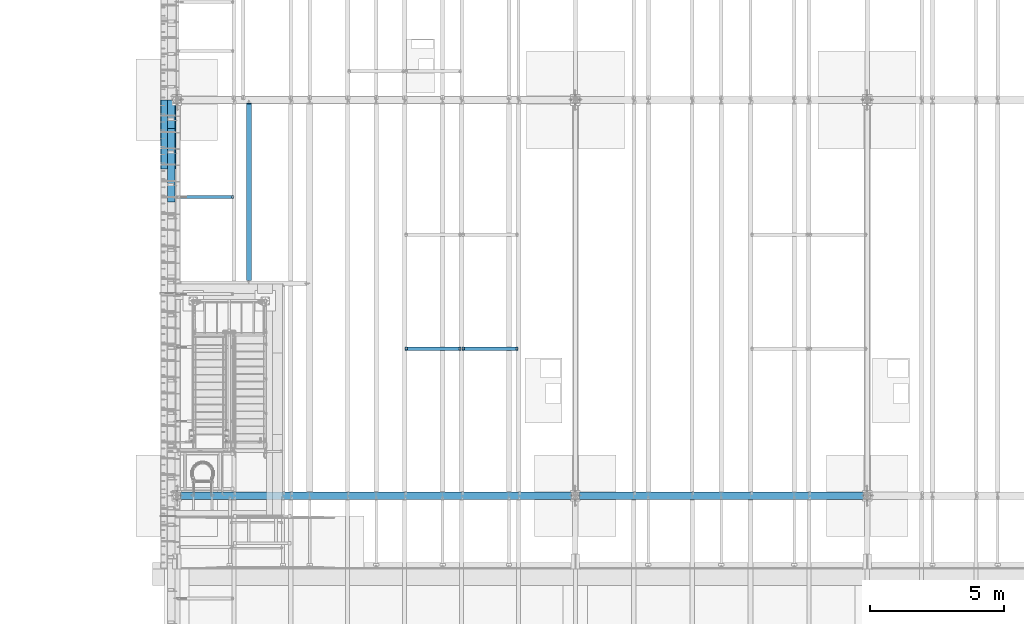
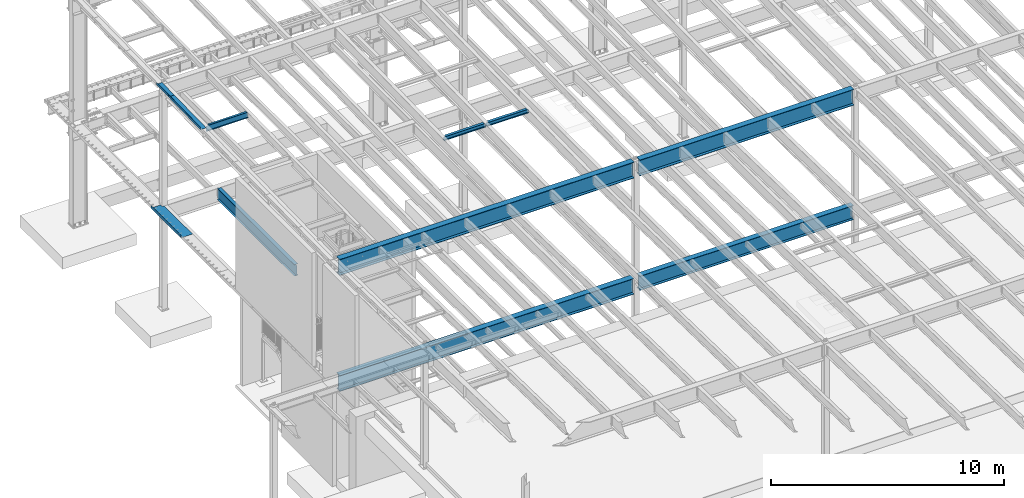
# One storey, part 1096 of 1763: 11 beams, 10 elements without a shape of their own.
"""IFC2X3 building model written with IfcOpenShell, lengths in millimetres."""

from ifc_helpers import new_model, si_unit, frame, origin_with_axes, place, context, subcontext, project, spatial, faceted_brep, material, type_object, element, aggregate, save


model = new_model("IFC2X3")

# Units and contexts
model_context = context("Model", 3, precision=1e-05, world=origin_with_axes())
body_context = subcontext(model_context, "Body", "Model", "MODEL_VIEW")
ifc_project = project(units=[si_unit("LENGTHUNIT", "METRE", prefix="MILLI"), si_unit("AREAUNIT", "SQUARE_METRE"), si_unit("VOLUMEUNIT", "CUBIC_METRE"), si_unit("MASSUNIT", "GRAM", prefix="KILO"), si_unit("TIMEUNIT", "SECOND"), si_unit("PLANEANGLEUNIT", "RADIAN"), si_unit("SOLIDANGLEUNIT", "STERADIAN"), si_unit("THERMODYNAMICTEMPERATUREUNIT", "DEGREE_CELSIUS"), si_unit("LUMINOUSINTENSITYUNIT", "LUMEN")], contexts=[model_context])

# Site, building, storey
site_placement = place(None, origin_with_axes())
site = spatial("IfcSite", under=ifc_project, at=site_placement, CompositionType="ELEMENT")
building_placement = place(site_placement, origin_with_axes())
building = spatial("IfcBuilding", under=site, at=building_placement, Name="Undefined", CompositionType="ELEMENT")
storey_placement = place(building_placement, origin_with_axes())
storey = spatial("IfcBuildingStorey", under=building, at=storey_placement, Name="Undefined", CompositionType="ELEMENT", Elevation=0.0)

# Assembly, beam
assembly_1_placement = place(storey_placement, origin_with_axes())
assembly_1 = element("IfcElementAssembly", 1, at=assembly_1_placement, inside=storey, Name="BEAM", AssemblyPlace="NOTDEFINED", PredefinedType="RIGID_FRAME")
ifc_material_1 = material(Name="STEEL/A992")
beam_type_1 = type_object("IfcBeamType", Name="W8X18", PredefinedType="NOTDEFINED")
beam_1_placement = place(assembly_1_placement, frame((-78870.0658451269, 35509.2, 11300.6242220873), z_axis=(0.0, 0.0, 1.0), x_axis=(1.0, 0.0, 0.0)))
beam_1 = element("IfcBeam", 2, at=beam_1_placement, type_object=beam_type_1, material=ifc_material_1, Name="BEAM", ObjectType="W8X18", context=body_context, shape_type="Brep", body=[
    faceted_brep([(2030.05010096592, -3.17500000000018, 68.5472454972532), (2030.05010096592, 3.17500000000018, 68.5472454972532), (2029.18911617418, 3.17500000000291, 69.8358002989789), (2029.18911617418, -3.17500000000291, 69.8358002989789), (2034.17027743408, -3.17500000000018, 65.7942315967757), (2034.17027743408, 3.17500000000018, 65.7942315967757), (2039.03035695212, -3.17500000000018, 64.8275016741882), (2039.03035695212, 3.17500000000018, 64.8275016741882), (2108.88035714286, -3.17500000000018, 64.8275016741882), (2108.88035714286, 3.17500000000018, 64.8275016741882), (2028.46260401768, -3.17500000000291, 70.3212402021363), (2028.46260401768, 3.17500000000291, 70.3212402021363), (2025.7095901172, 3.17500000000291, 74.44141667029), (2025.7095901172, -3.17500000000291, 74.44141667029), (2024.74286019462, 3.17500000000291, 79.3014961883364), (2024.74286019462, -3.17500000000291, 79.3014961883364), (2024.74286019463, 66.6750000000002, 95.25), (2024.74286019463, 3.17500000000018, 95.25), (101.599996948244, 3.17500000000018, 95.25), (101.599996948244, 66.6750000000002, 95.25), (2024.74286019463, -66.6750000000002, 95.25), (2024.74286019463, -66.6750000000002, 103.1875), (101.599996948244, -66.6750000000002, 103.1875), (101.599996948244, -66.6750000000002, 95.25), (2024.74286019463, 66.6750000000002, 103.1875), (101.599996948244, 66.6750000000002, 103.1875), (2024.74286019463, -3.17500000000018, 95.25), (101.599996948244, -3.17500000000018, 95.25), (101.599996948236, 3.17499999999927, 79.301496189446), (101.599996948236, -3.17499999999927, 79.301496189446), (100.633267025652, 3.17499999999927, 74.4414166713996), (100.633267025652, -3.17499999999927, 74.4414166713996), (97.8802531251713, 3.17499999999927, 70.3212402032459), (97.8802531251713, -3.17499999999927, 70.3212402032459), (97.153740969894, 3.17499999999927, 69.8358003008998), (97.153740969894, -3.17499999999927, 69.8358003008998), (96.2927561769247, 3.17500000000018, 68.5472454911378), (96.2927561769247, -3.17500000000018, 68.5472454911378), (92.1725797087711, 3.17500000000018, 65.7942315906603), (92.1725797087711, -3.17500000000018, 65.7942315906603), (87.3125001907247, 3.17500000000018, 64.8275016680727), (87.3125001907247, -3.17500000000018, 64.8275016680727), (17.4624999999905, 3.17500000000018, 64.8275016680727), (17.4624999999905, -3.17500000000018, 64.8275016680727), (17.4624999999905, 3.17500000000018, -95.25), (17.4624999999905, 66.6750000000002, -95.25), (17.4624999999905, 66.6750000000002, -103.1875), (17.4624999999905, -66.6750000000002, -103.1875), (17.4624999999905, -66.6750000000002, -95.25), (17.4624999999905, -3.17500000000018, -95.25), (2108.88035714286, 3.17500000000018, -95.25), (2108.88035714286, 66.6750000000002, -95.25), (2108.88035714286, 66.6750000000002, -103.1875), (2108.88035714286, -66.6750000000002, -103.1875), (2108.88035714286, -66.6750000000002, -95.25), (2108.88035714286, -3.17500000000018, -95.25)], [[[0, 1, 2, 3]], [[4, 5, 1, 0]], [[6, 7, 5, 4]], [[8, 9, 7, 6]], [[10, 11, 12, 13]], [[13, 12, 14, 15]], [[16, 17, 18, 19]], [[20, 21, 22, 23]], [[21, 24, 25, 22]], [[24, 16, 19, 25]], [[21, 20, 26, 15, 14, 17, 16, 24]], [[26, 20, 23, 27]], [[22, 25, 19, 18, 28, 29, 27, 23]], [[29, 28, 30, 31]], [[31, 30, 32, 33]], [[33, 32, 34, 35]], [[35, 34, 36, 37]], [[37, 36, 38, 39]], [[39, 38, 40, 41]], [[41, 40, 42, 43]], [[44, 45, 46, 47, 48, 49, 43, 42]], [[45, 44, 50, 51]], [[46, 45, 51, 52]], [[47, 46, 52, 53]], [[48, 47, 53, 54]], [[49, 48, 54, 55]], [[4, 0, 3, 10, 13, 15, 26, 27, 29, 31, 33, 35, 37, 39, 41, 43, 49, 55, 8, 6]], [[11, 10, 3, 2]], [[50, 44, 42, 40, 38, 36, 34, 32, 30, 28, 18, 17, 14, 12, 11, 2, 1, 5, 7, 9]], [[55, 54, 53, 52, 51, 50, 9, 8]]]),
])
aggregate(assembly_1, [beam_1])

assembly_2_placement = place(storey_placement, origin_with_axes())
assembly_2 = element("IfcElementAssembly", 3, at=assembly_2_placement, inside=storey, Name="BEAM", AssemblyPlace="NOTDEFINED", PredefinedType="RIGID_FRAME")
beam_2_placement = place(assembly_2_placement, frame((-76743.7229879841, 35509.2, 11300.6242220873), z_axis=(0.0, 0.0, 1.0), x_axis=(1.0, 0.0, 0.0)))
beam_2 = element("IfcBeam", 4, at=beam_2_placement, type_object=beam_type_1, material=ifc_material_1, Name="BEAM", ObjectType="W8X18", context=body_context, shape_type="Brep", body=[
    faceted_brep([(2030.05010096592, -3.17500000000018, 68.5472454972532), (2030.05010096592, 3.17500000000018, 68.5472454972532), (2029.18911617418, 3.17500000000291, 69.8358002989789), (2029.18911617418, -3.17500000000291, 69.8358002989789), (2034.17027743408, -3.17500000000018, 65.7942315967757), (2034.17027743408, 3.17500000000018, 65.7942315967757), (2039.03035695212, -3.17500000000018, 64.8275016741882), (2039.03035695212, 3.17500000000018, 64.8275016741882), (2108.88035714286, -3.17500000000018, 64.8275016741882), (2108.88035714286, 3.17500000000018, 64.8275016741882), (2028.46260401768, -3.17500000000291, 70.3212402021363), (2028.46260401768, 3.17500000000291, 70.3212402021363), (2025.7095901172, 3.17500000000291, 74.44141667029), (2025.7095901172, -3.17500000000291, 74.44141667029), (2024.74286019462, 3.17500000000291, 79.3014961883364), (2024.74286019462, -3.17500000000291, 79.3014961883364), (2024.74286019463, 66.6750000000002, 95.25), (2024.74286019463, 3.17500000000018, 95.25), (101.599996948244, 3.17500000000018, 95.25), (101.599996948244, 66.6750000000002, 95.25), (2024.74286019463, -66.6750000000002, 95.25), (2024.74286019463, -66.6750000000002, 103.1875), (101.599996948244, -66.6750000000002, 103.1875), (101.599996948244, -66.6750000000002, 95.25), (2024.74286019463, 66.6750000000002, 103.1875), (101.599996948244, 66.6750000000002, 103.1875), (2024.74286019463, -3.17500000000018, 95.25), (101.599996948244, -3.17500000000018, 95.25), (101.599996948236, 3.17499999999927, 79.301496189446), (101.599996948236, -3.17499999999927, 79.301496189446), (100.633267025652, 3.17499999999927, 74.4414166713996), (100.633267025652, -3.17499999999927, 74.4414166713996), (97.8802531251713, 3.17499999999927, 70.3212402032459), (97.8802531251713, -3.17499999999927, 70.3212402032459), (97.153740969894, 3.17499999999927, 69.8358003008998), (97.153740969894, -3.17499999999927, 69.8358003008998), (96.2927561769247, 3.17500000000018, 68.5472454911378), (96.2927561769247, -3.17500000000018, 68.5472454911378), (92.1725797087711, 3.17500000000018, 65.7942315906603), (92.1725797087711, -3.17500000000018, 65.7942315906603), (87.3125001907247, 3.17500000000018, 64.8275016680727), (87.3125001907247, -3.17500000000018, 64.8275016680727), (17.4624999999905, 3.17500000000018, 64.8275016680727), (17.4624999999905, -3.17500000000018, 64.8275016680727), (17.4624999999905, 3.17500000000018, -95.25), (17.4624999999905, 66.6750000000002, -95.25), (17.4624999999905, 66.6750000000002, -103.1875), (17.4624999999905, -66.6750000000002, -103.1875), (17.4624999999905, -66.6750000000002, -95.25), (17.4624999999905, -3.17500000000018, -95.25), (2108.88035714286, 3.17500000000018, -95.25), (2108.88035714286, 66.6750000000002, -95.25), (2108.88035714286, 66.6750000000002, -103.1875), (2108.88035714286, -66.6750000000002, -103.1875), (2108.88035714286, -66.6750000000002, -95.25), (2108.88035714286, -3.17500000000018, -95.25)], [[[0, 1, 2, 3]], [[4, 5, 1, 0]], [[6, 7, 5, 4]], [[8, 9, 7, 6]], [[10, 11, 12, 13]], [[13, 12, 14, 15]], [[16, 17, 18, 19]], [[20, 21, 22, 23]], [[21, 24, 25, 22]], [[24, 16, 19, 25]], [[21, 20, 26, 15, 14, 17, 16, 24]], [[26, 20, 23, 27]], [[22, 25, 19, 18, 28, 29, 27, 23]], [[29, 28, 30, 31]], [[31, 30, 32, 33]], [[33, 32, 34, 35]], [[35, 34, 36, 37]], [[37, 36, 38, 39]], [[39, 38, 40, 41]], [[41, 40, 42, 43]], [[44, 45, 46, 47, 48, 49, 43, 42]], [[45, 44, 50, 51]], [[46, 45, 51, 52]], [[47, 46, 52, 53]], [[48, 47, 53, 54]], [[49, 48, 54, 55]], [[4, 0, 3, 10, 13, 15, 26, 27, 29, 31, 33, 35, 37, 39, 41, 43, 49, 55, 8, 6]], [[11, 10, 3, 2]], [[50, 44, 42, 40, 38, 36, 34, 32, 30, 28, 18, 17, 14, 12, 11, 2, 1, 5, 7, 9]], [[55, 54, 53, 52, 51, 50, 9, 8]]]),
])
aggregate(assembly_2, [beam_2])

assembly_3_placement = place(storey_placement, origin_with_axes())
assembly_3 = element("IfcElementAssembly", 5, at=assembly_3_placement, inside=storey, Name="BEAM", AssemblyPlace="NOTDEFINED", PredefinedType="RIGID_FRAME")
ifc_material_2 = material(Name="STEEL/A36")
beam_type_2 = type_object("IfcBeamType", PredefinedType="NOTDEFINED")
beam_3_placement = place(assembly_3_placement, frame((-87413.5372736984, 43510.2, 5199.0625), z_axis=(0.0, -1.0, 0.0), x_axis=(-1.0, 0.0, 0.0)))
beam_3 = element("IfcBeam", 6, at=beam_3_placement, type_object=beam_type_2, material=ifc_material_2, Name="BENT_PLATE", context=body_context, shape_type="Brep", body=[
    faceted_brep([(103.187496948216, -4.76249999999982, -1150.93749743651), (103.187496948216, 4.76249999999982, -1150.93749743651), (103.187496948216, 4.76249999999982, -1292.2245), (103.187496948216, -4.76249999999982, -1292.2245), (0.0, -4.76249999999982, -1150.93749743651), (0.0, 4.76249999999982, -1150.93749743651), (571.5, 4.76249999999982, 1292.2245), (0.0, 4.76249999999982, 1292.2245), (0.0, -4.76249999999982, 1292.2245), (561.975000000006, -4.76249999999982, 1292.2245), (561.975000000006, -134.937496948242, 1292.2245), (571.5, -134.937496948242, 1292.2245), (571.5, 4.76249999999982, -1292.2245), (571.5, -134.937496948242, -1292.2245), (561.975000000006, -134.937496948242, -1292.2245), (561.975000000006, -4.76249999999982, -1292.2245)], [[[0, 1, 2, 3]], [[4, 5, 1, 0]], [[6, 7, 8, 9, 10, 11]], [[12, 6, 11, 13]], [[10, 14, 13, 11]], [[9, 15, 14, 10]], [[12, 13, 14, 15, 3, 2]], [[7, 6, 12, 2, 1, 5]], [[8, 7, 5, 4]], [[15, 9, 8, 4, 0, 3]]]),
])
aggregate(assembly_3, [beam_3])

# Assembly, beams
assembly_4_placement = place(storey_placement, origin_with_axes())
assembly_4 = element("IfcElementAssembly", 7, at=assembly_4_placement, inside=storey, Name="BEAM", AssemblyPlace="NOTDEFINED", PredefinedType="RIGID_FRAME")
beam_type_3 = type_object("IfcBeamType", PredefinedType="NOTDEFINED")
beam_4_placement = place(assembly_4_placement, frame((-87438.9372736983, 44273.9181491461, 11588.3263944835), z_axis=(0.0, -0.999786037781472, -0.0206852279954809), x_axis=(-1.0, 0.0, 0.0)))
beam_4 = element("IfcBeam", 8, at=beam_4_placement, type_object=beam_type_3, material=ifc_material_2, Name="BENT_PLATE", context=body_context, shape_type="Brep", body=[
    faceted_brep([(0.0, -3.17499999985739, -530.112000001536), (-1.45519152283669e-11, -3.17500000014115, 530.112000001522), (0.0, 3.17499999985557, 530.112000001522), (1.45519152283669e-11, 3.17500000013933, -530.112000001536), (285.750000000058, 3.17499999967185, 530.112000001522), (285.750000000102, 3.17499999995562, -530.112000001529), (279.400000000111, -3.17500000003747, -530.112000001529), (279.400000000067, -3.17500000031941, 530.112000001522), (285.750000000087, -123.824997298434, 530.112000001507), (285.750000000087, -123.824997298183, -530.112000001558), (279.400000000081, -123.824997298434, 530.112000001507), (279.400000000081, -123.824997298183, -530.112000001558)], [[[0, 1, 2, 3]], [[3, 2, 4, 5]], [[1, 0, 6, 7]], [[5, 4, 8, 9]], [[4, 2, 1, 7, 10, 8]], [[7, 6, 11, 10]], [[6, 0, 3, 5, 9, 11]], [[10, 11, 9, 8]]]),
])
beam_5_placement = place(assembly_4_placement, frame((-87438.9372736983, 42372.6130436667, 11548.9890481821), z_axis=(0.0, -0.999786037781472, -0.0206852279954809), x_axis=(-1.0, 0.0, 0.0)))
beam_5 = element("IfcBeam", 9, at=beam_5_placement, type_object=beam_type_3, material=ifc_material_2, Name="BENT_PLATE", context=body_context, shape_type="Brep", body=[
    faceted_brep([(2.91038304567337e-11, -3.17499999963729, -1371.60000000396), (-2.91038304567337e-11, -3.17500000036489, 1371.60000000395), (-2.91038304567337e-11, 3.17499999963184, 1371.60000000395), (2.91038304567337e-11, 3.17500000035943, -1371.60000000396), (285.75000000016, 3.17499999930078, 1371.59999999897), (285.750000000276, 3.17499999982283, -1371.59999999897), (279.400000000271, -3.1750000001648, -1371.59999999897), (279.400000000154, -3.17500000068321, 1371.59999999897), (285.750000000218, -123.824997298658, 1371.59999999895), (285.750000000218, -123.824997298212, -1371.59999999898), (279.400000000212, -123.824997298658, 1371.59999999895), (279.400000000212, -123.824997298212, -1371.59999999898)], [[[0, 1, 2, 3]], [[3, 2, 4, 5]], [[1, 0, 6, 7]], [[5, 4, 8, 9]], [[4, 2, 1, 7, 10, 8]], [[7, 6, 11, 10]], [[6, 0, 3, 5, 9, 11]], [[10, 11, 9, 8]]]),
])
aggregate(assembly_4, [beam_4, beam_5])

# Assembly, beam
assembly_5_placement = place(storey_placement, origin_with_axes())
assembly_5 = element("IfcElementAssembly", 10, at=assembly_5_placement, inside=storey, Name="BEAM", AssemblyPlace="NOTDEFINED", PredefinedType="RIGID_FRAME")
beam_type_4 = type_object("IfcBeamType", Name="W12X22", PredefinedType="NOTDEFINED")
beam_6_placement = place(assembly_5_placement, frame((-87375.4372736983, 41182.925, 11365.624133767), z_axis=(0.0, 0.0, 1.0), x_axis=(1.0, 0.0, 0.0)))
beam_6 = element("IfcBeam", 11, at=beam_6_placement, type_object=beam_type_4, material=ifc_material_1, Name="BEAM", ObjectType="W12X22", context=body_context, shape_type="Brep", body=[
    faceted_brep([(18.2562499999913, -3.17499999999927, -144.4625), (18.2562499999913, -50.7999999999993, -144.4625), (2109.67410714286, -50.7999999999993, -144.4625), (2109.67410714286, -3.17499999999927, -144.4625), (18.2562499999913, -50.7999999999993, -155.575000000001), (2109.67410714286, -50.7999999999993, -155.575000000001), (2109.67410714286, 3.17499999999927, -144.4625), (2109.67410714286, 50.7999999999993, -144.4625), (132.556249999994, 50.7999999999993, -144.4625), (132.556249999994, 3.17575008238782, -144.4625), (2033.47410714286, -50.7999999999993, 155.575000000001), (2033.47410714286, -50.7999999999993, 144.4625), (2033.47410714286, -3.17499999999927, 144.4625), (2033.47410714286, -3.17499999999927, 136.265001487105), (2033.47410714286, 3.17499999999927, 136.265001487105), (2033.47410714286, 3.17499999999927, 144.4625), (2033.47410714286, 50.7999999999993, 144.4625), (2033.47410714286, 50.7999999999993, 155.575000000001), (2034.44083706544, -3.17499999999927, 131.404921969059), (2034.44083706544, 3.17499999999927, 131.404921969059), (2037.19385096592, -3.17499999999927, 127.284745500905), (2037.19385096592, 3.17499999999927, 127.284745500905), (2041.31402743408, -3.17499999999927, 124.531731600428), (2041.31402743408, 3.17499999999927, 124.531731600428), (2046.17410695212, -3.17499999999927, 123.56500167784), (2046.17410695212, 3.17499999999927, 123.56500167784), (2109.67410714286, -3.17499999999927, 123.56500167784), (2109.67410714286, 3.17499999999927, 123.56500167784), (2109.67410714286, 50.7999999999993, -155.575000000001), (132.556249999994, 50.7999999999993, -155.575000000001), (132.556249999994, 3.17575008238782, -155.575000000001), (18.2562499999913, 3.17575008238782, -155.575000000001), (18.2562499999913, 3.17499999999927, -144.4625), (124.716329708754, -3.17499999999927, 105.741729925645), (124.716329708754, 3.17500736736474, 105.741729925645), (119.856250190714, 3.1750086254724, 104.775000003057), (119.856250190714, -3.17499999999927, 104.775000003057), (128.836506176915, -3.17499999999927, 108.494743826122), (128.836506176915, 3.17500378457771, 108.494743826122), (131.589520077396, -3.17499999999927, 112.614920294276), (131.589520077396, 3.17499842256075, 112.614920294276), (132.55624999998, -3.17499999999927, 117.474999812322), (132.55624999998, 3.17499209762536, 117.474999812322), (18.2562499999913, 3.17499999999927, -137.353076309833), (18.2562499999913, 3.17499999999927, 104.775000003057), (132.55624999998, 3.17499999999927, 144.4625), (132.55624999998, 50.7999999999993, 144.4625), (132.55624999998, 50.7999999999993, 155.575000000001), (132.55624999998, -50.7999999999993, 155.575000000001), (132.55624999998, -50.7999999999993, 144.4625), (132.55624999998, -3.17499999999927, 144.4625), (18.2562499999913, -3.17499999999927, 104.775000003057)], [[[0, 1, 2, 3]], [[1, 4, 5, 2]], [[6, 7, 8, 9]], [[10, 11, 12, 13, 14, 15, 16, 17]], [[18, 19, 14, 13]], [[20, 21, 19, 18]], [[22, 23, 21, 20]], [[24, 25, 23, 22]], [[26, 27, 25, 24]], [[3, 2, 5, 28, 7, 6, 27, 26]], [[7, 28, 29, 8]], [[8, 29, 30, 9]], [[28, 5, 4, 31, 30, 29]], [[9, 30, 31, 32]], [[33, 34, 35, 36]], [[37, 38, 34, 33]], [[39, 40, 38, 37]], [[41, 42, 40, 39]], [[15, 14, 19, 21, 23, 25, 27, 6, 9, 32, 43, 44, 35, 34, 38, 40, 42, 45]], [[16, 15, 45, 46]], [[17, 16, 46, 47]], [[10, 17, 47, 48]], [[11, 10, 48, 49]], [[12, 11, 49, 50]], [[48, 47, 46, 45, 42, 41, 50, 49]], [[39, 37, 33, 36, 51, 0, 3, 26, 24, 22, 20, 18, 13, 12, 50, 41]], [[43, 32, 31, 4, 1, 0, 51, 44]], [[36, 35, 44, 51]]]),
])
aggregate(assembly_5, [beam_6])

assembly_6_placement = place(storey_placement, origin_with_axes())
assembly_6 = element("IfcElementAssembly", 12, at=assembly_6_placement, inside=storey, Name="BEAM", AssemblyPlace="NOTDEFINED", PredefinedType="RIGID_FRAME")
beam_type_5 = type_object("IfcBeamType", Name="W24X55", PredefinedType="NOTDEFINED")
beam_7_placement = place(assembly_6_placement, frame((-84684.7417063673, 37947.6, 4894.2625), z_axis=(0.0, 0.0, 1.0), x_axis=(0.0, 1.0, 0.0)))
beam_7 = element("IfcBeam", 13, at=beam_7_placement, type_object=beam_type_5, material=ifc_material_1, Name="BEAM", ObjectType="W24X55", context=body_context, shape_type="Brep", body=[
    faceted_brep([(17.4624999999942, -4.76249999999709, -271.7225), (17.4624999999942, 4.76249999999709, -271.7225), (93.6625001907305, 4.76249999999709, -271.7225), (93.6625001907305, -4.76249999999709, -271.7225), (98.5225797087769, 4.76249999999709, -272.689229922587), (98.5225797087769, -4.76249999999709, -272.689229922587), (102.642756176931, 4.76249999999709, -275.442243823066), (102.642756176931, -4.76249999999709, -275.442243823066), (105.395770077404, 4.76249999999709, -279.562420291219), (105.395770077404, -4.76249999999709, -279.562420291219), (106.362499999996, -4.76249999999709, -284.422499809265), (106.362499999996, 4.76249999999709, -284.422499809265), (106.362499999996, 4.76249999999709, -287.3375), (106.362499999996, 88.8999999999942, -287.3375), (106.362499999996, 88.8999999999942, -300.0375), (106.362499999996, -88.8999999999942, -300.0375), (106.362499999996, -88.8999999999942, -287.3375), (106.362499999996, -4.76249999999709, -287.3375), (6698.45624999997, 88.8999999999942, 287.3375), (6698.45624999997, 4.76249999999709, 287.3375), (106.362499999996, 4.76249999999709, 287.3375), (106.362499999996, 88.8999999999942, 287.3375), (93.6625001907305, -4.76249999999709, 268.027501678467), (93.6625001907305, 4.76249999999709, 268.027501678467), (17.4624999999942, 4.76249999999709, 268.027501678467), (17.4624999999942, -4.76249999999709, 268.027501678467), (98.5225797087769, -4.76249999999709, 268.994231601055), (98.5225797087769, 4.76249999999709, 268.994231601055), (102.642756176931, -4.76249999999709, 271.747245501533), (102.642756176931, 4.76249999999709, 271.747245501533), (105.395770077404, -4.76249999999709, 275.867421969687), (105.395770077404, 4.76249999999709, 275.867421969687), (106.362499999996, -4.76249999999709, 280.727501487732), (106.362499999996, 4.76249999999709, 280.727501487732), (6698.45624999997, -88.8999999999942, 300.0375), (6698.45624999997, 88.8999999999942, 300.0375), (106.362499999996, 88.8999999999942, 300.0375), (106.362499999996, -88.8999999999942, 300.0375), (6698.45624999997, -88.8999999999942, 287.3375), (106.362499999996, -88.8999999999942, 287.3375), (6698.45624999997, -4.76249999999709, 287.3375), (106.362499999996, -4.76249999999709, 287.3375), (6698.45624999997, -4.76249999999709, 280.727501487732), (6698.45624999997, 4.76249999999709, 280.727501487732), (6699.42297992256, -4.76249999999709, 275.867421969687), (6699.42297992256, 4.76249999999709, 275.867421969687), (6702.17599382304, -4.76249999999709, 271.747245501533), (6702.17599382304, 4.76249999999709, 271.747245501533), (6706.29617029119, -4.76249999999709, 268.994231601055), (6706.29617029119, 4.76249999999709, 268.994231601055), (6711.15624980924, -4.76249999999709, 268.027501678467), (6711.15624980924, 4.76249999999709, 268.027501678467), (6838.15624999999, -4.76249999999709, 268.027501678467), (6838.15624999999, 4.76249999999709, 268.027501678467), (6736.55624872205, -88.8999999999942, -287.3375), (6736.55624872205, -88.8999999999942, -300.0375), (6736.55622725979, -5.06274543626932, -300.0375), (6736.55622725969, -5.0622513936396, -287.3375), (6838.15624999999, -5.06222538421571, -287.3375), (6838.15624999999, -5.06271942691819, -300.0375), (6736.55622624891, 5.0627455276117, -287.3375), (6736.556226249, 5.06225148496742, -300.0375), (6736.55620478676, 88.8999999999942, -300.0375), (6736.55620478676, 88.8999999999942, -287.3375), (6838.15624999999, 5.06277153702104, -287.3375), (6838.15624999999, 5.06227749431855, -300.0375), (6838.15624999999, 4.76249999999709, -287.3375), (6838.15624999999, -4.76249999999709, -287.3375)], [[[0, 1, 2, 3]], [[3, 2, 4, 5]], [[5, 4, 6, 7]], [[7, 6, 8, 9]], [[10, 11, 12, 13, 14, 15, 16, 17]], [[9, 8, 11, 10]], [[18, 19, 20, 21]], [[22, 23, 24, 25]], [[26, 27, 23, 22]], [[28, 29, 27, 26]], [[30, 31, 29, 28]], [[32, 33, 31, 30]], [[34, 35, 36, 37]], [[38, 34, 37, 39]], [[40, 38, 39, 41]], [[37, 36, 21, 20, 33, 32, 41, 39]], [[35, 18, 21, 36]], [[34, 38, 40, 42, 43, 19, 18, 35]], [[44, 45, 43, 42]], [[46, 47, 45, 44]], [[48, 49, 47, 46]], [[50, 51, 49, 48]], [[52, 53, 51, 50]], [[54, 55, 56, 57]], [[58, 57, 56, 59]], [[60, 61, 62, 63]], [[64, 65, 61, 60]], [[66, 53, 52, 67, 58, 59, 65, 64]], [[54, 57, 58, 67, 17, 16]], [[55, 54, 16, 15]], [[62, 61, 65, 59, 56, 55, 15, 14]], [[63, 62, 14, 13]], [[66, 64, 60, 63, 13, 12]], [[6, 4, 2, 1, 24, 23, 27, 29, 31, 33, 20, 19, 43, 45, 47, 49, 51, 53, 66, 12, 11, 8]], [[25, 24, 1, 0]], [[67, 52, 50, 48, 46, 44, 42, 40, 41, 32, 30, 28, 26, 22, 25, 0, 3, 5, 7, 9, 10, 17]]]),
])
aggregate(assembly_6, [beam_7])

assembly_7_placement = place(storey_placement, origin_with_axes())
assembly_7 = element("IfcElementAssembly", 14, at=assembly_7_placement, inside=storey, Name="BEAM", AssemblyPlace="NOTDEFINED", PredefinedType="RIGID_FRAME")
beam_type_6 = type_object("IfcBeamType", Name="W33X130", PredefinedType="NOTDEFINED")
beam_8_placement = place(assembly_7_placement, frame((-87375.4372736983, 30022.8000001297, 10869.6124999957), z_axis=(0.0, 0.0, 1.0), x_axis=(1.0, 0.0, 0.0)))
beam_8 = element("IfcBeam", 15, at=beam_8_placement, type_object=beam_type_6, material=ifc_material_1, Name="BEAM", ObjectType="W33X130", context=body_context, shape_type="Brep", body=[
    faceted_brep([(141.287500000006, 146.049999999999, -420.6875), (141.287499999999, 146.049999999999, -398.4625), (14743.1125, 146.049999999999, -398.4625), (14743.1125, 146.049999999999, -420.6875), (141.287499999999, 7.14374999999927, -398.4625), (14743.1125, 7.14374999999927, -398.4625), (141.287499999999, 7.14374999999927, 398.4625), (14743.1125, 7.14374999999927, 398.4625), (141.287499999999, 146.049999999999, 398.4625), (14743.1125, 146.049999999999, 398.4625), (141.287500000006, 146.049999999999, 420.6875), (14743.1125, 146.049999999999, 420.6875), (141.287500000006, -146.049999999999, 420.6875), (14743.1125, -146.049999999999, 420.6875), (141.287499999999, -146.049999999999, 398.4625), (14743.1125, -146.049999999999, 398.4625), (141.287499999999, -7.14374999999927, 398.4625), (14743.1125, -7.14374999999927, 398.4625), (141.287499999999, -7.14374999999927, -398.4625), (14743.1125, -7.14374999999927, -398.4625), (141.287499999999, -146.049999999999, -398.4625), (14743.1125, -146.049999999999, -398.4625), (141.287500000006, -146.049999999999, -420.6875), (14743.1125, -146.049999999999, -420.6875)], [[[0, 1, 2, 3]], [[1, 4, 5, 2]], [[4, 6, 7, 5]], [[6, 8, 9, 7]], [[8, 10, 11, 9]], [[10, 12, 13, 11]], [[12, 14, 15, 13]], [[14, 16, 17, 15]], [[16, 18, 19, 17]], [[18, 20, 21, 19]], [[20, 22, 23, 21]], [[22, 0, 3, 23]], [[5, 7, 9, 11, 13, 15, 17, 19, 21, 23, 3, 2]], [[22, 20, 18, 16, 14, 12, 10, 8, 6, 4, 1, 0]]]),
])
aggregate(assembly_7, [beam_8])

assembly_8_placement = place(storey_placement, origin_with_axes())
assembly_8 = element("IfcElementAssembly", 16, at=assembly_8_placement, inside=storey, Name="BEAM", AssemblyPlace="NOTDEFINED", PredefinedType="RIGID_FRAME")
beam_type_7 = type_object("IfcBeamType", Name="W33X118", PredefinedType="NOTDEFINED")
beam_9_placement = place(assembly_8_placement, frame((-72491.0372736984, 30022.8000001297, 10872.7874999957), z_axis=(0.0, 0.0, 1.0), x_axis=(1.0, 0.0, 0.0)))
beam_9 = element("IfcBeam", 17, at=beam_9_placement, type_object=beam_type_7, material=ifc_material_1, Name="BEAM", ObjectType="W33X118", context=body_context, shape_type="Brep", body=[
    faceted_brep([(141.287499999999, 146.049999999999, -417.512500000001), (141.287499999999, 146.049999999999, -398.4625), (10755.3125, 146.049999999999, -398.4625), (10755.3125, 146.049999999999, -417.512500000001), (141.287499999999, 7.14374999999927, -398.4625), (10755.3125, 7.14374999999927, -398.4625), (141.287499999999, 7.14374999999927, 398.4625), (10755.3125, 7.14374999999927, 398.4625), (141.287499999999, 146.049999999999, 398.4625), (10755.3125, 146.049999999999, 398.4625), (141.287499999999, 146.049999999999, 417.512500000001), (10755.3125, 146.049999999999, 417.512500000001), (141.287499999999, -146.049999999999, 417.512500000001), (10755.3125, -146.049999999999, 417.512500000001), (141.287499999999, -146.049999999999, 398.4625), (10755.3125, -146.049999999999, 398.4625), (141.287499999999, -7.14374999999927, 398.4625), (10755.3125, -7.14374999999927, 398.4625), (141.287499999999, -7.14374999999927, -398.4625), (10755.3125, -7.14374999999927, -398.4625), (141.287499999999, -146.049999999999, -398.4625), (10755.3125, -146.049999999999, -398.4625), (141.287499999999, -146.049999999999, -417.512500000001), (10755.3125, -146.049999999999, -417.512500000001)], [[[0, 1, 2, 3]], [[1, 4, 5, 2]], [[4, 6, 7, 5]], [[6, 8, 9, 7]], [[8, 10, 11, 9]], [[10, 12, 13, 11]], [[12, 14, 15, 13]], [[14, 16, 17, 15]], [[16, 18, 19, 17]], [[18, 20, 21, 19]], [[20, 22, 23, 21]], [[22, 0, 3, 23]], [[5, 7, 9, 11, 13, 15, 17, 19, 21, 23, 3, 2]], [[22, 20, 18, 16, 14, 12, 10, 8, 6, 4, 1, 0]]]),
])
aggregate(assembly_8, [beam_9])

assembly_9_placement = place(storey_placement, origin_with_axes())
assembly_9 = element("IfcElementAssembly", 18, at=assembly_9_placement, inside=storey, Name="BEAM", AssemblyPlace="NOTDEFINED", PredefinedType="RIGID_FRAME")
beam_10_placement = place(assembly_9_placement, frame((-87375.4372736983, 30022.8, 4776.7875), z_axis=(0.0, 0.0, 1.0), x_axis=(1.0, 0.0, 0.0)))
beam_10 = element("IfcBeam", 19, at=beam_10_placement, type_object=beam_type_7, material=ifc_material_1, Name="BEAM", ObjectType="W33X118", context=body_context, shape_type="Brep", body=[
    faceted_brep([(141.287499999999, 146.049999999999, -417.512500000001), (141.287499999999, 146.049999999999, -398.4625), (14743.1125, 146.049999999999, -398.4625), (14743.1125, 146.050000000003, -417.5125), (141.287499999999, 7.14374999999927, -398.4625), (14743.1125, 7.14374999999927, -398.4625), (141.287499999999, 7.14374999999927, 398.4625), (14743.1125, 7.14374999999927, 398.4625), (141.287499999999, 146.049999999999, 398.4625), (14743.1125, 146.049999999999, 398.4625), (141.287499999999, 146.049999999999, 417.512500000001), (14743.1125, 146.050000000003, 417.5125), (141.287499999999, -146.049999999999, 417.512500000001), (14743.1125, -146.050000000003, 417.5125), (141.287499999999, -146.049999999999, 398.4625), (14743.1125, -146.049999999999, 398.4625), (141.287499999999, -7.14374999999927, 398.4625), (14743.1125, -7.14374999999927, 398.4625), (141.287499999999, -7.14374999999927, -398.4625), (14743.1125, -7.14374999999927, -398.4625), (141.287499999999, -146.049999999999, -398.4625), (14743.1125, -146.049999999999, -398.4625), (141.287499999999, -146.049999999999, -417.512500000001), (14743.1125, -146.050000000003, -417.5125)], [[[0, 1, 2, 3]], [[1, 4, 5, 2]], [[4, 6, 7, 5]], [[6, 8, 9, 7]], [[8, 10, 11, 9]], [[10, 12, 13, 11]], [[12, 14, 15, 13]], [[14, 16, 17, 15]], [[16, 18, 19, 17]], [[18, 20, 21, 19]], [[20, 22, 23, 21]], [[22, 0, 3, 23]], [[5, 7, 9, 11, 13, 15, 17, 19, 21, 23, 3, 2]], [[22, 20, 18, 16, 14, 12, 10, 8, 6, 4, 1, 0]]]),
])
aggregate(assembly_9, [beam_10])

assembly_10_placement = place(storey_placement, origin_with_axes())
assembly_10 = element("IfcElementAssembly", 20, at=assembly_10_placement, inside=storey, Name="BEAM", AssemblyPlace="NOTDEFINED", PredefinedType="RIGID_FRAME")
beam_type_8 = type_object("IfcBeamType", Name="W30X99", PredefinedType="NOTDEFINED")
beam_11_placement = place(assembly_10_placement, frame((-72491.0372736984, 30022.8, 4818.0625), z_axis=(0.0, 0.0, 1.0), x_axis=(1.0, 0.0, 0.0)))
beam_11 = element("IfcBeam", 21, at=beam_11_placement, type_object=beam_type_8, material=ifc_material_1, Name="BEAM", ObjectType="W30X99", context=body_context, shape_type="Brep", body=[
    faceted_brep([(141.287499999999, 133.349999999999, -376.237499999999), (141.287499999999, 133.349999999999, -358.775), (10755.3125, 133.349999999999, -358.775), (10755.3125, 133.349999999999, -376.2375), (141.287500000006, 6.34999999999854, -358.775), (10755.3125, 6.34999999999854, -358.775), (141.287500000006, 6.34999999999854, 358.775), (10755.3125, 6.34999999999854, 358.775), (141.287499999999, 133.349999999999, 358.775), (10755.3125, 133.349999999999, 358.775), (141.287499999999, 133.349999999999, 376.237499999999), (10755.3125, 133.349999999999, 376.2375), (141.287499999999, -133.349999999999, 376.237499999999), (10755.3125, -133.349999999999, 376.2375), (141.287499999999, -133.349999999999, 358.775), (10755.3125, -133.349999999999, 358.775), (141.287500000006, -6.34999999999854, 358.775), (10755.3125, -6.34999999999854, 358.775), (141.287500000006, -6.34999999999854, -358.775), (10755.3125, -6.34999999999854, -358.775), (141.287499999999, -133.349999999999, -358.775), (10755.3125, -133.349999999999, -358.775), (141.287499999999, -133.349999999999, -376.237499999999), (10755.3125, -133.349999999999, -376.2375)], [[[0, 1, 2, 3]], [[1, 4, 5, 2]], [[4, 6, 7, 5]], [[6, 8, 9, 7]], [[8, 10, 11, 9]], [[10, 12, 13, 11]], [[12, 14, 15, 13]], [[14, 16, 17, 15]], [[16, 18, 19, 17]], [[18, 20, 21, 19]], [[20, 22, 23, 21]], [[22, 0, 3, 23]], [[5, 7, 9, 11, 13, 15, 17, 19, 21, 23, 3, 2]], [[22, 20, 18, 16, 14, 12, 10, 8, 6, 4, 1, 0]]]),
])
aggregate(assembly_10, [beam_11])

save(model, "model.ifc")
